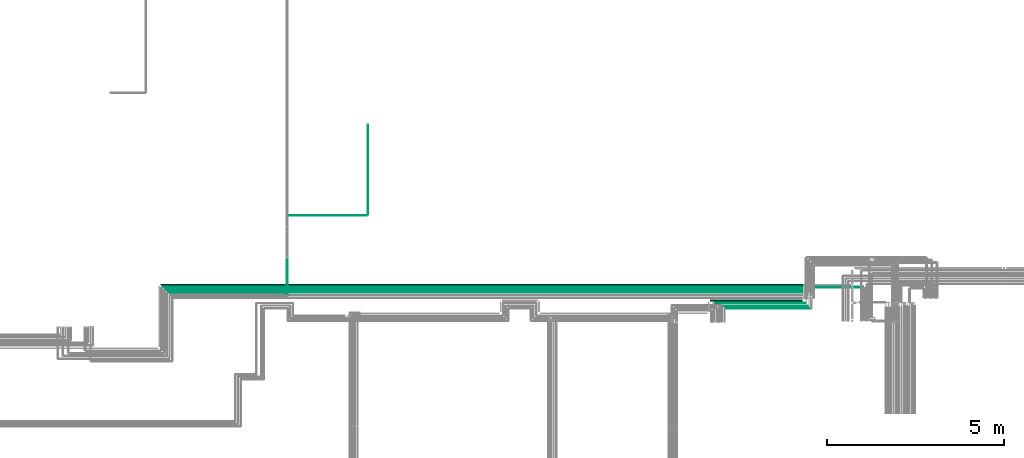
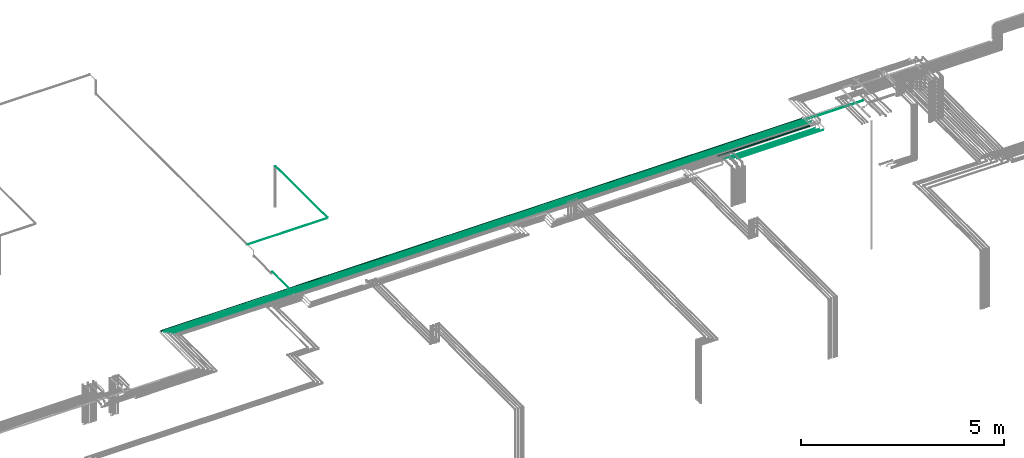
# One storey, part 17 of 65: 11 flow segments.
"""IFC2X3 building model written with IfcOpenShell, lengths in millimetres."""

from ifc_helpers import new_model, entity, si_unit, converted_unit, derived_unit, direction, frame, frame_2d, origin, origin_2d_with_axis, place, context, subcontext, project, spatial, circle, extrude, type_object, element, save


model = new_model("IFC2X3")

# Units and contexts
model_context = context("Model", 3, precision=0.01, world=origin(), true_north=direction((6.12303176911189e-17, 1.0)))
body_context = subcontext(model_context, "Body", "Model", "MODEL_VIEW")
ifc_project = project(units=[si_unit("LENGTHUNIT", "METRE", prefix="MILLI"), si_unit("AREAUNIT", "SQUARE_METRE"), si_unit("VOLUMEUNIT", "CUBIC_METRE"), converted_unit("PLANEANGLEUNIT", "DEGREE", entity("IfcRatioMeasure", 0.0174532925199433), si_unit("PLANEANGLEUNIT", "RADIAN"), dimensions=[0, 0, 0, 0, 0, 0, 0]), si_unit("MASSUNIT", "GRAM", prefix="KILO"), derived_unit("MASSDENSITYUNIT", [(si_unit("MASSUNIT", "GRAM", prefix="KILO"), 1), (si_unit("LENGTHUNIT", "METRE"), -3)]), derived_unit("MOMENTOFINERTIAUNIT", [(si_unit("LENGTHUNIT", "METRE"), 4)]), si_unit("TIMEUNIT", "SECOND"), si_unit("FREQUENCYUNIT", "HERTZ"), si_unit("THERMODYNAMICTEMPERATUREUNIT", "DEGREE_CELSIUS"), derived_unit("THERMALTRANSMITTANCEUNIT", [(si_unit("MASSUNIT", "GRAM", prefix="KILO"), 1), (si_unit("THERMODYNAMICTEMPERATUREUNIT", "KELVIN"), -1), (si_unit("TIMEUNIT", "SECOND"), -3)]), derived_unit("VOLUMETRICFLOWRATEUNIT", [(si_unit("LENGTHUNIT", "METRE"), 3), (si_unit("TIMEUNIT", "SECOND"), -1)]), derived_unit("MASSFLOWRATEUNIT", [(si_unit("MASSUNIT", "GRAM", prefix="KILO"), 1), (si_unit("TIMEUNIT", "SECOND"), -1)]), derived_unit("ROTATIONALFREQUENCYUNIT", [(si_unit("TIMEUNIT", "SECOND"), -1)]), si_unit("ELECTRICCURRENTUNIT", "AMPERE"), si_unit("ELECTRICVOLTAGEUNIT", "VOLT"), si_unit("POWERUNIT", "WATT"), si_unit("FORCEUNIT", "NEWTON", prefix="KILO"), si_unit("ILLUMINANCEUNIT", "LUX"), si_unit("LUMINOUSFLUXUNIT", "LUMEN"), si_unit("LUMINOUSINTENSITYUNIT", "CANDELA"), derived_unit("USERDEFINED", [(si_unit("MASSUNIT", "GRAM", prefix="KILO"), -1), (si_unit("LENGTHUNIT", "METRE"), -2), (si_unit("TIMEUNIT", "SECOND"), 3), (si_unit("LUMINOUSFLUXUNIT", "LUMEN"), 1)]), derived_unit("LINEARVELOCITYUNIT", [(si_unit("LENGTHUNIT", "METRE"), 1), (si_unit("TIMEUNIT", "SECOND"), -1)]), si_unit("PRESSUREUNIT", "PASCAL"), derived_unit("USERDEFINED", [(si_unit("LENGTHUNIT", "METRE"), -2), (si_unit("MASSUNIT", "GRAM", prefix="KILO"), 1), (si_unit("TIMEUNIT", "SECOND"), -2)]), derived_unit("LINEARFORCEUNIT", [(si_unit("MASSUNIT", "GRAM", prefix="KILO"), 1), (si_unit("LENGTHUNIT", "METRE"), 1), (si_unit("TIMEUNIT", "SECOND"), -2), (si_unit("LENGTHUNIT", "METRE"), -1)]), derived_unit("PLANARFORCEUNIT", [(si_unit("MASSUNIT", "GRAM", prefix="KILO"), 1), (si_unit("LENGTHUNIT", "METRE"), 1), (si_unit("TIMEUNIT", "SECOND"), -2), (si_unit("LENGTHUNIT", "METRE"), -2)])], contexts=[model_context])

# Site, building, storey
site_placement = place(None, frame((0.0, -0.00077364408347762, 0.0)))
site = spatial("IfcSite", under=ifc_project, at=site_placement, CompositionType="ELEMENT")
building_placement = place(site_placement, origin())
building = spatial("IfcBuilding", under=site, at=building_placement, CompositionType="ELEMENT")
storey_placement = place(building_placement, frame((0.0, 0.0, 19800.0)))
storey = spatial("IfcBuildingStorey", under=building, at=storey_placement, CompositionType="ELEMENT", Elevation=19800.0)

# Flow segments
pipe_segment_type = type_object("IfcPipeSegmentType", PredefinedType="NOTDEFINED")
flow_segment_1_placement = place(storey_placement, frame((45569.1221386505, 8612.40493375773, 2462.40472776408)))
element("IfcFlowSegment", 1, at=flow_segment_1_placement, inside=storey, type_object=pipe_segment_type, context=body_context, shape_type="SweptSolid", body=[
    extrude(circle(Radius=11.0, at=frame_2d((-1.84087411980727e-11, 0.0), x_axis=(1.0, 0.0))), frame((0.0, 12.595272235934, 12.5952722359177), z_axis=(1.0, 0.0, 0.0), x_axis=(0.0, 1.0, 0.0)), (0.0, 0.0, 1.0), 19831.9897446271),
])
flow_segment_2_placement = place(storey_placement, frame((45510.1221386505, 8680.90493375773, 2455.90472776409)))
element("IfcFlowSegment", 2, at=flow_segment_2_placement, inside=storey, type_object=pipe_segment_type, context=body_context, shape_type="SweptSolid", body=[
    extrude(circle(Radius=17.5, at=origin_2d_with_axis()), frame((0.0, 19.0952722359163, 19.0952722359163), z_axis=(1.0, 0.0, 0.0), x_axis=(0.0, 1.0, 0.0)), (0.0, 0.0, 1.0), 18178.9372055938),
])
flow_segment_3_placement = place(storey_placement, frame((61489.9005160426, 8017.40493375773, 2467.40472776407)))
element("IfcFlowSegment", 3, at=flow_segment_3_placement, inside=storey, type_object=pipe_segment_type, context=body_context, shape_type="SweptSolid", body=[
    extrude(circle(Radius=6.0, at=origin_2d_with_axis()), frame((0.0, 7.59527223591562, 7.59527223591454), z_axis=(1.0, 0.0, 0.0), x_axis=(0.0, 1.0, 0.0)), (0.0, 0.0, 1.0), 2431.15882820169),
])
flow_segment_4_placement = place(storey_placement, frame((61343.9005160427, 8090.90493375773, 2465.90472776406)))
element("IfcFlowSegment", 4, at=flow_segment_4_placement, inside=storey, type_object=pipe_segment_type, context=body_context, shape_type="SweptSolid", body=[
    extrude(circle(Radius=7.5, at=frame_2d((-1.08286712929839e-12, 0.0), x_axis=(1.0, 0.0))), frame((0.0, 9.09527223591744, 9.09527223591419), z_axis=(1.0, 0.0, 0.0), x_axis=(0.0, 1.0, 0.0)), (0.0, 0.0, 1.0), 2498.15882820167),
])
flow_segment_5_placement = place(storey_placement, frame((61193.9005160427, 8165.90493375773, 2465.90472776406)))
element("IfcFlowSegment", 5, at=flow_segment_5_placement, inside=storey, type_object=pipe_segment_type, context=body_context, shape_type="SweptSolid", body=[
    extrude(circle(Radius=7.5, at=frame_2d((-1.08286712929839e-12, 0.0), x_axis=(1.0, 0.0))), frame((0.0, 9.09527223591744, 9.09527223591419), z_axis=(1.0, 0.0, 0.0), x_axis=(0.0, 1.0, 0.0)), (0.0, 0.0, 1.0), 2573.15882820169),
])
flow_segment_6_placement = place(storey_placement, frame((61065.9005160427, 8230.90493375772, 2530.90472776409)))
element("IfcFlowSegment", 6, at=flow_segment_6_placement, inside=storey, type_object=pipe_segment_type, context=body_context, shape_type="SweptSolid", body=[
    extrude(circle(Radius=17.5, at=frame_2d((-5.41433564649196e-12, 0.0), x_axis=(1.0, 0.0))), frame((0.0, 19.0952722359217, 19.0952722359163), z_axis=(1.0, 0.0, 0.0), x_axis=(0.0, 1.0, 0.0)), (0.0, 0.0, 1.0), 2604.1588282017),
])
flow_segment_7_placement = place(storey_placement, frame((45715.1221386505, 8465.90493375771, 2465.90472776413)))
element("IfcFlowSegment", 7, at=flow_segment_7_placement, inside=storey, type_object=pipe_segment_type, context=body_context, shape_type="SweptSolid", body=[
    extrude(circle(Radius=7.5, at=frame_2d((-4.22318180426373e-11, 0.0), x_axis=(1.0, 0.0))), frame((0.0, 9.09527223595859, 9.09527223591419), z_axis=(1.0, 0.0, 0.0), x_axis=(0.0, 1.0, 0.0)), (0.0, 0.0, 1.0), 18124.9372055938),
])
flow_segment_8_placement = place(storey_placement, frame((45638.1221386505, 8540.90493375773, 2465.90472776413)))
element("IfcFlowSegment", 8, at=flow_segment_8_placement, inside=storey, type_object=pipe_segment_type, context=body_context, shape_type="SweptSolid", body=[
    extrude(circle(Radius=7.5, at=frame_2d((-3.35688810082502e-11, 0.0), x_axis=(1.0, 0.0))), frame((0.0, 9.09527223594993, 9.09527223591419), z_axis=(1.0, 0.0, 0.0), x_axis=(0.0, 1.0, 0.0)), (0.0, 0.0, 1.0), 18128.9372055938),
])
flow_segment_9_placement = place(storey_placement, frame((49085.9032995414, 8418.00020599364, 2540.9047277641)))
element("IfcFlowSegment", 9, at=flow_segment_9_placement, inside=storey, type_object=pipe_segment_type, context=body_context, shape_type="SweptSolid", body=[
    extrude(circle(Radius=7.5, at=origin_2d_with_axis()), frame((9.09527223591419, 0.0, 9.09527223591419), z_axis=(0.0, 1.0, 0.0), x_axis=(1.0, 0.0, 0.0)), (0.0, 0.0, 1.0), 1013.99987685239),
])
flow_segment_10_placement = place(storey_placement, frame((49108.9985717773, 10652.4049337577, 2617.40472776407)))
element("IfcFlowSegment", 10, at=flow_segment_10_placement, inside=storey, type_object=pipe_segment_type, context=body_context, shape_type="SweptSolid", body=[
    extrude(circle(Radius=6.0, at=origin_2d_with_axis()), frame((0.0, 7.5952722359167, 7.59527223591454), z_axis=(1.0, 0.0, 0.0), x_axis=(0.0, 1.0, 0.0)), (0.0, 0.0, 1.0), 2241.65331651179),
])
flow_segment_11_placement = place(storey_placement, frame((51365.5566160532, 10678.0002059936, 2615.90472776407)))
element("IfcFlowSegment", 11, at=flow_segment_11_placement, inside=storey, type_object=pipe_segment_type, context=body_context, shape_type="SweptSolid", body=[
    extrude(circle(Radius=7.5, at=origin_2d_with_axis()), frame((9.09527223591419, 0.0, 9.09527223591419), z_axis=(0.0, 1.0, 0.0), x_axis=(1.0, 0.0, 0.0)), (0.0, 0.0, 1.0), 2542.61311591022),
])

save(model, "model.ifc")
